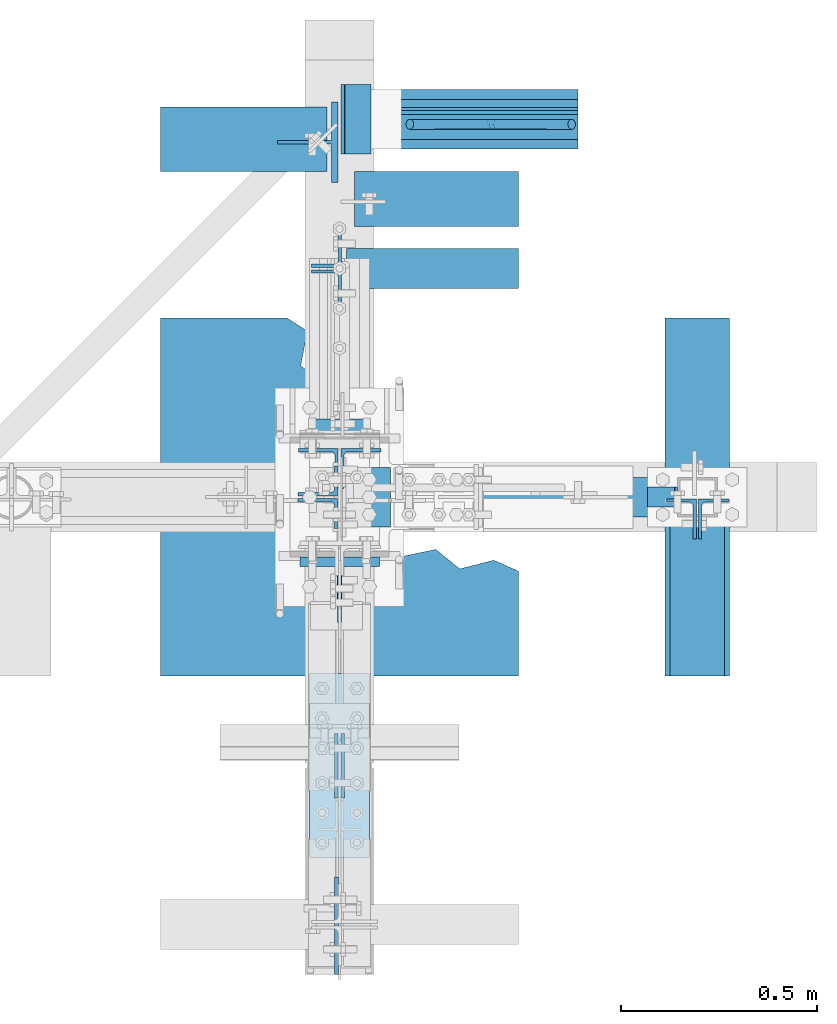
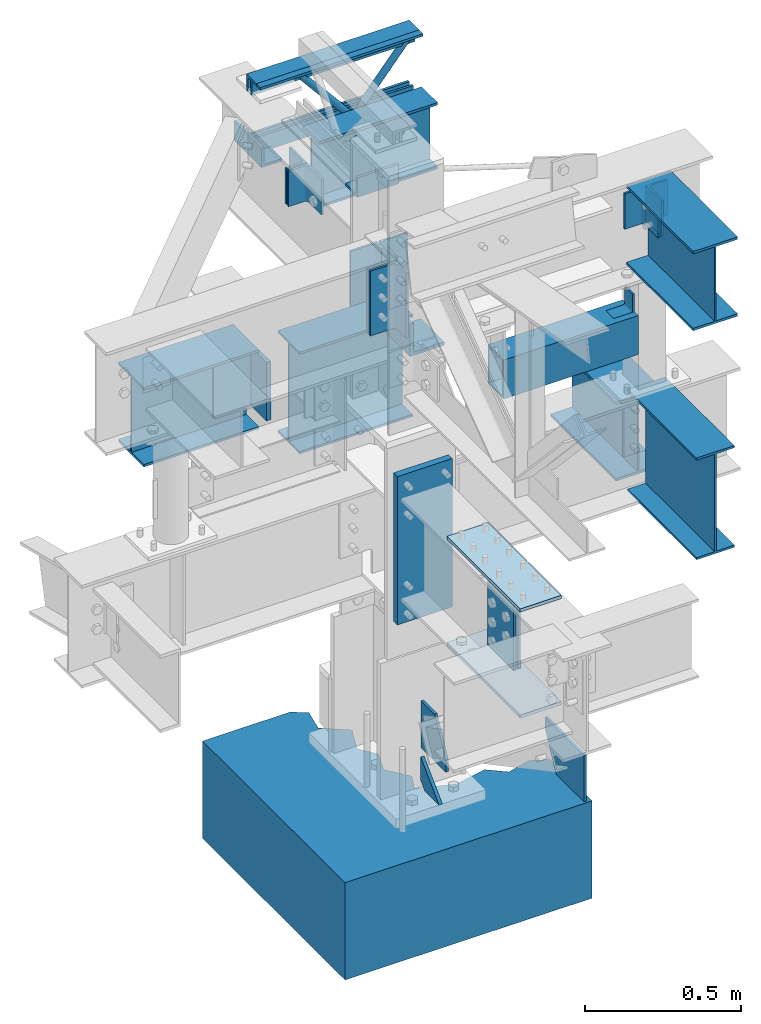
# Not in any storey, part 3 of 7: 18 members, 9 plates, 7 beams, 17 elements without a shape of their own.
"""IFC2X3 building model written with IfcOpenShell, lengths in inches."""

from ifc_helpers import new_model, entity, si_unit, converted_unit, frame, frame_2d, origin_with_axes, place, context, project, spatial, polyline, hollow_rectangle, i_section, l_section, t_section, outline, transform_2d, derived_profile, extrude, source, transform, mapped, material, type_object, type_shapes, element, aggregate, save


model = new_model("IFC2X3")

# Units and contexts
model_context = context("Model", 3, precision=1e-05, world=origin_with_axes())
ifc_project = project(units=[converted_unit("LENGTHUNIT", "INCH", entity("IfcLengthMeasure", 25.4), si_unit("LENGTHUNIT", "METRE", prefix="MILLI"), dimensions=[1, 0, 0, 0, 0, 0, 0]), si_unit("PLANEANGLEUNIT", "RADIAN"), si_unit("MASSUNIT", "GRAM", prefix="KILO"), si_unit("TIMEUNIT", "SECOND"), si_unit("AREAUNIT", "SQUARE_METRE"), si_unit("PRESSUREUNIT", "PASCAL"), si_unit("FORCEUNIT", "NEWTON"), si_unit("THERMODYNAMICTEMPERATUREUNIT", "DEGREE_CELSIUS")], contexts=[model_context])

# Site, building
site_placement = place(None, origin_with_axes())
site = spatial("IfcSite", under=ifc_project, at=site_placement, CompositionType="ELEMENT")
building_placement = place(site_placement, origin_with_axes())
building = spatial("IfcBuilding", under=site, at=building_placement, Name="Building", CompositionType="ELEMENT")

# Assembly, members
assembly_1_placement = place(building_placement, frame((0.0, 38.0, 82.5), z_axis=(0.0, 0.0, -1.0), x_axis=(1.0, 0.0, 0.0)))
assembly_1 = element("IfcElementAssembly", 1, at=assembly_1_placement, inside=building, Name="M_41", PredefinedType="NOTDEFINED")
ifc_material_1 = material()
member_type_1 = type_object("IfcMemberType", Name="L2-1/2x2-1/2x3/8", PredefinedType="USERDEFINED", material=ifc_material_1)
shared_shape_1 = source(origin_with_axes(), model_context, "Body", "SweptSolid", [
    extrude(l_section(Depth=2.5, Width=2.5, Thickness=0.375, FilletRadius=0.3125, at=frame_2d((1.25, 1.25), x_axis=(1.0, 0.0))), frame((0.0, 0.0, 0.0), z_axis=(1.0, 0.0, 0.0), x_axis=(0.0, 1.0, 0.0)), (0.0, 0.0, 1.0), 23.7500038146973),
])
type_shapes(member_type_1, [shared_shape_1])
member_1_placement = place(assembly_1_placement, frame((0.25, 0.5, 0.0), z_axis=(0.0, 0.0, 1.0), x_axis=(1.0, 0.0, 0.0)))
member_1 = element("IfcMember", 2, at=member_1_placement, type_object=member_type_1, Name="a32", ObjectType="Member", context=model_context, shape_type="MappedRepresentation", body=[
    mapped(shared_shape_1, transform((0.0, 0.0, 0.0), scale=1.0)),
])
member_type_2 = type_object("IfcMemberType", Name="L2-1/2x2-1/2x3/8", PredefinedType="USERDEFINED", material=ifc_material_1)
shared_shape_2 = source(origin_with_axes(), model_context, "Body", "SweptSolid", [
    extrude(derived_profile(l_section(Depth=2.5, Width=2.5, Thickness=0.375, FilletRadius=0.3125, at=frame_2d((1.25, 1.25), x_axis=(1.0, 0.0))), transform_2d((0.0, 0.0), x_axis=(-1.0, 0.0), y_axis=(0.0, 1.0))), frame((0.0, 0.0, 0.0), z_axis=(1.0, 0.0, 0.0), x_axis=(0.0, 1.0, 0.0)), (0.0, 0.0, 1.0), 23.7500038146973),
])
type_shapes(member_type_2, [shared_shape_2])
member_2_placement = place(assembly_1_placement, frame((0.25, -0.5, 0.0), z_axis=(0.0, 0.0, 1.0), x_axis=(1.0, 0.0, 0.0)))
member_2 = element("IfcMember", 3, at=member_2_placement, type_object=member_type_2, Name="a6", ObjectType="Member", context=model_context, shape_type="MappedRepresentation", body=[
    mapped(shared_shape_2, transform((0.0, 0.0, 0.0), scale=1.0)),
])
member_type_3 = type_object("IfcMemberType", Name="L2-1/2x2-1/2x3/8", PredefinedType="USERDEFINED", material=ifc_material_1)
shared_shape_3 = source(origin_with_axes(), model_context, "Body", "SweptSolid", [
    extrude(derived_profile(l_section(Depth=2.5, Width=2.5, Thickness=0.375, FilletRadius=0.3125, at=frame_2d((1.25, 1.25), x_axis=(1.0, 0.0))), transform_2d((0.0, 0.0), x_axis=(-1.0, 0.0), y_axis=(0.0, 1.0))), frame((0.0, 0.0, 0.0), z_axis=(1.0, 0.0, 0.0), x_axis=(0.0, 1.0, 0.0)), (0.0, 0.0, 1.0), 23.5000038146973),
])
type_shapes(member_type_3, [shared_shape_3])
member_3_placement = place(assembly_1_placement, frame((0.5, 0.5, 12.0), z_axis=(0.0, 0.0, -1.0), x_axis=(1.0, 0.0, 0.0)))
member_3 = element("IfcMember", 4, at=member_3_placement, type_object=member_type_3, Name="a37", ObjectType="Member", context=model_context, shape_type="MappedRepresentation", body=[
    mapped(shared_shape_3, transform((0.0, 0.0, 0.0), scale=1.0)),
])
member_type_4 = type_object("IfcMemberType", Name="L2-1/2x2-1/2x3/8", PredefinedType="USERDEFINED", material=ifc_material_1)
shared_shape_4 = source(origin_with_axes(), model_context, "Body", "SweptSolid", [
    extrude(l_section(Depth=2.5, Width=2.5, Thickness=0.375, FilletRadius=0.3125, at=frame_2d((1.25, 1.25), x_axis=(1.0, 0.0))), frame((0.0, 0.0, 0.0), z_axis=(1.0, 0.0, 0.0), x_axis=(0.0, 1.0, 0.0)), (0.0, 0.0, 1.0), 23.5000038146973),
])
type_shapes(member_type_4, [shared_shape_4])
member_4_placement = place(assembly_1_placement, frame((24.0000038146973, -0.5, 12.0), z_axis=(0.0, -1.0, 0.0), x_axis=(-1.0, 0.0, 0.0)))
member_4 = element("IfcMember", 5, at=member_4_placement, type_object=member_type_4, Name="a38", ObjectType="Member", context=model_context, shape_type="MappedRepresentation", body=[
    mapped(shared_shape_4, transform((0.0, 0.0, 0.0), scale=1.0)),
])

assembly_2_placement = place(building_placement, frame((0.0, 0.0, 54.5), z_axis=(0.0, -1.0, 0.0), x_axis=(0.0, 0.0, 1.0)))
assembly_2 = element("IfcElementAssembly", 6, at=assembly_2_placement, inside=building, Name="1-3", PredefinedType="NOTDEFINED")
member_type_5 = type_object("IfcMemberType", Name="L5x5x1/2", PredefinedType="USERDEFINED", material=ifc_material_1)
shared_shape_5 = source(origin_with_axes(), model_context, "Body", "SweptSolid", [
    extrude(derived_profile(l_section(Depth=5.0, Width=5.0, Thickness=0.5, FilletRadius=0.5, at=frame_2d((2.5, 2.5), x_axis=(1.0, 0.0))), transform_2d((0.0, 0.0), x_axis=(-1.0, 0.0), y_axis=(0.0, 1.0))), frame((0.0, 0.0, 0.0), z_axis=(1.0, 0.0, 0.0), x_axis=(0.0, 1.0, 0.0)), (0.0, 0.0, 1.0), 6.0),
])
type_shapes(member_type_5, [shared_shape_5])
member_5_placement = place(assembly_2_placement, frame((9.64000034332275, -0.144999995827675, 3.0), z_axis=(0.0, -1.0, 0.0), x_axis=(0.0, 0.0, -1.0)))
member_5 = element("IfcMember", 7, at=member_5_placement, type_object=member_type_5, Name="a28", ObjectType="Column", context=model_context, shape_type="MappedRepresentation", body=[
    mapped(shared_shape_5, transform((0.0, 0.0, 0.0), scale=1.0)),
])
member_type_6 = type_object("IfcMemberType", Name="L3x3x3/8", PredefinedType="USERDEFINED", material=ifc_material_1)
shared_shape_6 = source(origin_with_axes(), model_context, "Body", "SweptSolid", [
    extrude(derived_profile(l_section(Depth=3.0, Width=3.0, Thickness=0.375, FilletRadius=0.3125, at=frame_2d((1.5, 1.5), x_axis=(1.0, 0.0))), transform_2d((0.0, 0.0), x_axis=(-1.0, 0.0), y_axis=(0.0, 1.0))), frame((0.0, 0.0, 0.0), z_axis=(1.0, 0.0, 0.0), x_axis=(0.0, 1.0, 0.0)), (0.0, 0.0, 1.0), 6.0),
])
type_shapes(member_type_6, [shared_shape_6])
member_6_placement = place(assembly_2_placement, frame((30.5, -3.0, -4.86499977111816), z_axis=(0.0, 0.0, -1.0), x_axis=(0.0, 1.0, 0.0)))
member_6 = element("IfcMember", 8, at=member_6_placement, type_object=member_type_6, Name="a27", ObjectType="Column", context=model_context, shape_type="MappedRepresentation", body=[
    mapped(shared_shape_6, transform((0.0, 0.0, 0.0), scale=1.0)),
])
aggregate(assembly_2, [member_5, member_6])

# Assembly, member
assembly_3_placement = place(building_placement, frame((0.0, 0.0, 46.0), z_axis=(0.0, 0.0, 1.0), x_axis=(0.0, 1.0, 0.0)))
assembly_3 = element("IfcElementAssembly", 9, at=assembly_3_placement, inside=building, Name="2-3", PredefinedType="NOTDEFINED")
ifc_material_2 = material()
member_type_7 = type_object("IfcMemberType", Name="WT6x25", PredefinedType="USERDEFINED", material=ifc_material_2)
shared_shape_7 = source(origin_with_axes(), model_context, "Body", "SweptSolid", [
    extrude(t_section(Depth=6.095, FlangeWidth=8.08, WebThickness=0.37, FlangeThickness=0.64, at=frame_2d((0.0, -3.0475), x_axis=(1.0, 0.0))), frame((0.0, 0.0, 0.0), z_axis=(1.0, 0.0, 0.0), x_axis=(0.0, 1.0, 0.0)), (0.0, 0.0, 1.0), 9.0),
])
type_shapes(member_type_7, [shared_shape_7])
member_7_placement = place(assembly_3_placement, frame((35.6999999880791, 0.14750000834465, -12.5), z_axis=(0.0, -1.0, 0.0), x_axis=(0.0, 0.0, 1.0)))
member_7 = element("IfcMember", 10, at=member_7_placement, type_object=member_type_7, Name="wt5", ObjectType="Beam", context=model_context, shape_type="MappedRepresentation", body=[
    mapped(shared_shape_7, transform((0.0, 0.0, 0.0), scale=1.0)),
])
aggregate(assembly_3, [member_7])

# Assembly, beam
assembly_4_placement = place(building_placement, frame((36.0, 0.0, 58.0), z_axis=(0.0, 0.0, 1.0), x_axis=(-1.0, 0.0, 0.0)))
assembly_4 = element("IfcElementAssembly", 11, at=assembly_4_placement, inside=building, Name="4-3", PredefinedType="NOTDEFINED")
ifc_material_3 = material()
beam_type_1 = type_object("IfcBeamType", Name="TS6x4x1/4", PredefinedType="BEAM", material=ifc_material_3)
shared_shape_8 = source(origin_with_axes(), model_context, "Body", "SweptSolid", [
    extrude(hollow_rectangle(XDim=4.0, YDim=6.0, WallThickness=0.25, at=frame_2d((0.0, -3.0), x_axis=(1.0, 0.0))), frame((0.0, 0.0, 0.0), z_axis=(1.0, 0.0, 0.0), x_axis=(0.0, 1.0, 0.0)), (0.0, 0.0, 1.0), 19.625),
])
type_shapes(beam_type_1, [shared_shape_8])
beam_1_placement = place(assembly_4_placement, frame((21.625, 0.0, 0.0), z_axis=(0.0, 0.0, 1.0), x_axis=(-1.0, 0.0, 0.0)))
beam_1 = element("IfcBeam", 12, at=beam_1_placement, type_object=beam_type_1, Name="ts3", ObjectType="Beam", context=model_context, shape_type="MappedRepresentation", body=[
    mapped(shared_shape_8, transform((0.0, 0.0, 0.0), scale=1.0)),
])
aggregate(assembly_4, [beam_1])

# Assembly, member
assembly_5_placement = place(building_placement, frame((36.0, 0.0, 46.0), z_axis=(-1.0, 0.0, 0.0), x_axis=(0.0, 0.0, 1.0)))
assembly_5 = element("IfcElementAssembly", 13, at=assembly_5_placement, inside=building, Name="4-1", PredefinedType="NOTDEFINED")
member_type_8 = type_object("IfcMemberType", Name="L3x3x1/4", PredefinedType="USERDEFINED", material=ifc_material_1)
shared_shape_9 = source(origin_with_axes(), model_context, "Body", "SweptSolid", [
    extrude(derived_profile(l_section(Depth=3.0, Width=3.0, Thickness=0.25, FilletRadius=0.3125, at=frame_2d((1.5, 1.5), x_axis=(1.0, 0.0))), transform_2d((0.0, 0.0), x_axis=(-1.0, 0.0), y_axis=(0.0, 1.0))), frame((0.0, 0.0, 0.0), z_axis=(1.0, 0.0, 0.0), x_axis=(0.0, 1.0, 0.0)), (0.0, 0.0, 1.0), 2.0),
])
type_shapes(member_type_8, [shared_shape_9])
member_8_placement = place(assembly_5_placement, frame((11.75, 1.0, 2.0), z_axis=(0.0, 0.0, 1.0), x_axis=(0.0, -1.0, 0.0)))
member_8 = element("IfcMember", 14, at=member_8_placement, type_object=member_type_8, Name="a11", ObjectType="Column", context=model_context, shape_type="MappedRepresentation", body=[
    mapped(shared_shape_9, transform((0.0, 0.0, 0.0), scale=1.0)),
])
aggregate(assembly_5, [member_8])

# Assembly, beam
assembly_6_placement = place(building_placement, frame((36.0, 0.0, 46.0), z_axis=(0.0, 0.0, 1.0), x_axis=(0.0, -1.0, 0.0)))
assembly_6 = element("IfcElementAssembly", 15, at=assembly_6_placement, inside=building, Name="3-1", PredefinedType="NOTDEFINED")
ifc_material_4 = material()
beam_type_2 = type_object("IfcBeamType", Name="W16x26", PredefinedType="BEAM", material=ifc_material_4)
shared_shape_10 = source(origin_with_axes(), model_context, "Body", "SweptSolid", [
    extrude(i_section(OverallWidth=5.5, OverallDepth=15.69, WebThickness=0.25, FlangeThickness=0.345, at=frame_2d((0.0, -7.845), x_axis=(1.0, 0.0))), frame((0.0, 0.0, 0.0), z_axis=(1.0, 0.0, 0.0), x_axis=(0.0, 1.0, 0.0)), (0.0, 0.0, 1.0), 17.4375),
])
type_shapes(beam_type_2, [shared_shape_10])
beam_2_placement = place(assembly_6_placement, frame((0.5625, 0.0, 0.0), z_axis=(0.0, 0.0, 1.0), x_axis=(1.0, 0.0, 0.0)))
beam_2 = element("IfcBeam", 16, at=beam_2_placement, type_object=beam_type_2, Name="w3", ObjectType="Beam", context=model_context, shape_type="MappedRepresentation", body=[
    mapped(shared_shape_10, transform((0.0, 0.0, 0.0), scale=1.0)),
])
aggregate(assembly_6, [beam_2])

assembly_7_placement = place(building_placement, frame((36.0, 0.0, 43.0), z_axis=(0.0, 0.0, 1.0), x_axis=(0.0, 1.0, 0.0)))
assembly_7 = element("IfcElementAssembly", 17, at=assembly_7_placement, inside=building, Name="3-3", PredefinedType="NOTDEFINED")
beam_type_3 = type_object("IfcBeamType", Name="W12x26", PredefinedType="BEAM", material=ifc_material_4)
shared_shape_11 = source(origin_with_axes(), model_context, "Body", "SweptSolid", [
    extrude(i_section(OverallWidth=6.49, OverallDepth=12.22, WebThickness=0.23, FlangeThickness=0.38, at=frame_2d((0.0, -6.11), x_axis=(1.0, 0.0))), frame((0.0, 0.0, 0.0), z_axis=(1.0, 0.0, 0.0), x_axis=(0.0, 1.0, 0.0)), (0.0, 0.0, 1.0), 16.5),
])
type_shapes(beam_type_3, [shared_shape_11])
beam_3_placement = place(assembly_7_placement, frame((1.5, 0.0, 0.0), z_axis=(0.0, 0.0, 1.0), x_axis=(1.0, 0.0, 0.0)))
beam_3 = element("IfcBeam", 18, at=beam_3_placement, type_object=beam_type_3, Name="w13", ObjectType="Beam", context=model_context, shape_type="MappedRepresentation", body=[
    mapped(shared_shape_11, transform((0.0, 0.0, 0.0), scale=1.0)),
])
aggregate(assembly_7, [beam_3])

assembly_8_placement = place(building_placement, frame((0.0, 30.0, 46.0), z_axis=(0.0, 0.0, 1.0), x_axis=(1.0, 0.0, 0.0)))
assembly_8 = element("IfcElementAssembly", 19, at=assembly_8_placement, inside=building, Name="3-2", PredefinedType="NOTDEFINED")
beam_type_4 = type_object("IfcBeamType", Name="W16x26", PredefinedType="BEAM", material=ifc_material_4)
shared_shape_12 = source(origin_with_axes(), model_context, "Body", "SweptSolid", [
    extrude(i_section(OverallWidth=5.5, OverallDepth=15.69, WebThickness=0.25, FlangeThickness=0.345, at=frame_2d((0.0, -7.845), x_axis=(1.0, 0.0))), frame((0.0, 0.0, 0.0), z_axis=(1.0, 0.0, 0.0), x_axis=(0.0, 1.0, 0.0)), (0.0, 0.0, 1.0), 16.5),
])
type_shapes(beam_type_4, [shared_shape_12])
beam_4_placement = place(assembly_8_placement, frame((1.5, 0.0, 0.0), z_axis=(0.0, 0.0, 1.0), x_axis=(1.0, 0.0, 0.0)))
beam_4 = element("IfcBeam", 20, at=beam_4_placement, type_object=beam_type_4, Name="w16", ObjectType="Beam", context=model_context, shape_type="MappedRepresentation", body=[
    mapped(shared_shape_12, transform((0.0, 0.0, 0.0), scale=1.0)),
])
aggregate(assembly_8, [beam_4])

assembly_9_placement = place(building_placement, frame((0.0, 36.0, 44.0), z_axis=(0.0, 0.0, 1.0), x_axis=(-1.0, 0.0, 0.0)))
assembly_9 = element("IfcElementAssembly", 21, at=assembly_9_placement, inside=building, Name="3-4", PredefinedType="NOTDEFINED")
beam_type_5 = type_object("IfcBeamType", Name="W12x26", PredefinedType="BEAM", material=ifc_material_4)
shared_shape_13 = source(origin_with_axes(), model_context, "Body", "SweptSolid", [
    extrude(i_section(OverallWidth=6.49, OverallDepth=12.22, WebThickness=0.23, FlangeThickness=0.38, at=frame_2d((0.0, -6.11), x_axis=(1.0, 0.0))), frame((0.0, 0.0, 0.0), z_axis=(1.0, 0.0, 0.0), x_axis=(0.0, 1.0, 0.0)), (0.0, 0.0, 1.0), 16.75),
])
type_shapes(beam_type_5, [shared_shape_13])
beam_5_placement = place(assembly_9_placement, frame((1.25, 0.0, 0.0), z_axis=(0.0, 0.0, 1.0), x_axis=(1.0, 0.0, 0.0)))
beam_5 = element("IfcBeam", 22, at=beam_5_placement, type_object=beam_type_5, Name="w18", ObjectType="Beam", context=model_context, shape_type="MappedRepresentation", body=[
    mapped(shared_shape_13, transform((0.0, 0.0, 0.0), scale=1.0)),
])
aggregate(assembly_9, [beam_5])

# Assembly, members
assembly_10_placement = place(building_placement, frame((0.0, 23.0, 82.5), z_axis=(0.0, 0.0, 1.0), x_axis=(1.0, 0.0, 0.0)))
assembly_10 = element("IfcElementAssembly", 23, at=assembly_10_placement, inside=building, Name="3-11", PredefinedType="NOTDEFINED")
member_type_9 = type_object("IfcMemberType", Name="L4x3x5/16", PredefinedType="USERDEFINED", material=ifc_material_1)
shared_shape_14 = source(origin_with_axes(), model_context, "Body", "SweptSolid", [
    extrude(derived_profile(l_section(Depth=4.0, Width=3.0, Thickness=0.3125, FilletRadius=0.4375, at=frame_2d((1.5, 2.0), x_axis=(1.0, 0.0))), transform_2d((0.0, 0.0), x_axis=(-1.0, 0.0), y_axis=(0.0, 1.0))), frame((0.0, 0.0, 0.0), z_axis=(1.0, 0.0, 0.0), x_axis=(0.0, 1.0, 0.0)), (0.0, 0.0, 1.0), 5.5),
])
type_shapes(member_type_9, [shared_shape_14])
member_9_placement = place(assembly_10_placement, frame((0.1875, -0.125, -9.75), z_axis=(0.0, -1.0, 0.0), x_axis=(0.0, 0.0, 1.0)))
member_9 = element("IfcMember", 24, at=member_9_placement, type_object=member_type_9, Name="a31", ObjectType="Beam", context=model_context, shape_type="MappedRepresentation", body=[
    mapped(shared_shape_14, transform((0.0, 0.0, 0.0), scale=1.0)),
])
member_10_placement = place(assembly_10_placement, frame((0.1875, 0.125, -4.25), z_axis=(0.0, 1.0, 0.0), x_axis=(0.0, 0.0, -1.0)))
member_10 = element("IfcMember", 25, at=member_10_placement, type_object=member_type_9, Name="a31", ObjectType="Beam", context=model_context, shape_type="MappedRepresentation", body=[
    mapped(shared_shape_14, transform((0.0, 0.0, 0.0), scale=1.0)),
])

assembly_11_placement = place(building_placement, frame((0.0, 0.0, 80.0), z_axis=(0.0, 0.0, 1.0), x_axis=(0.0, 1.0, 0.0)))
assembly_11 = element("IfcElementAssembly", 26, at=assembly_11_placement, inside=building, Name="2-6", PredefinedType="NOTDEFINED")
member_type_10 = type_object("IfcMemberType", Name="L4x4x5/16", PredefinedType="USERDEFINED", material=ifc_material_1)
shared_shape_15 = source(origin_with_axes(), model_context, "Body", "SweptSolid", [
    extrude(derived_profile(l_section(Depth=4.0, Width=4.0, Thickness=0.3125, FilletRadius=0.375, at=frame_2d((2.0, 2.0), x_axis=(1.0, 0.0))), transform_2d((0.0, 0.0), x_axis=(-1.0, 0.0), y_axis=(0.0, 1.0))), frame((0.0, 0.0, 0.0), z_axis=(1.0, 0.0, 0.0), x_axis=(0.0, 1.0, 0.0)), (0.0, 0.0, 1.0), 8.5),
])
type_shapes(member_type_10, [shared_shape_15])
member_11_placement = place(assembly_11_placement, frame((4.875, -0.14750000834465, -11.25), z_axis=(0.0, -1.0, 0.0), x_axis=(0.0, 0.0, 1.0)))
member_11 = element("IfcMember", 27, at=member_11_placement, type_object=member_type_10, Name="a7", ObjectType="Beam", context=model_context, shape_type="MappedRepresentation", body=[
    mapped(shared_shape_15, transform((0.0, 0.0, 0.0), scale=1.0)),
])
member_12_placement = place(assembly_11_placement, frame((4.875, 0.14750000834465, -2.75), z_axis=(0.0, 1.0, 0.0), x_axis=(0.0, 0.0, -1.0)))
member_12 = element("IfcMember", 28, at=member_12_placement, type_object=member_type_10, Name="a7", ObjectType="Beam", context=model_context, shape_type="MappedRepresentation", body=[
    mapped(shared_shape_15, transform((0.0, 0.0, 0.0), scale=1.0)),
])

assembly_12_placement = place(building_placement, frame((0.0, 0.0, 80.0), z_axis=(0.0, 0.0, 1.0), x_axis=(-1.0, 0.0, 0.0)))
assembly_12 = element("IfcElementAssembly", 29, at=assembly_12_placement, inside=building, Name="2-7", PredefinedType="NOTDEFINED")
member_type_11 = type_object("IfcMemberType", Name="L4x3x5/16", PredefinedType="USERDEFINED", material=ifc_material_1)
shared_shape_16 = source(origin_with_axes(), model_context, "Body", "SweptSolid", [
    extrude(l_section(Depth=4.0, Width=3.0, Thickness=0.3125, FilletRadius=0.4375, at=frame_2d((1.5, 2.0), x_axis=(1.0, 0.0))), frame((0.0, 0.0, 0.0), z_axis=(1.0, 0.0, 0.0), x_axis=(0.0, 1.0, 0.0)), (0.0, 0.0, 1.0), 10.0),
])
type_shapes(member_type_11, [shared_shape_16])
member_13_placement = place(assembly_12_placement, frame((0.1875, -0.137500002980232, -12.75), z_axis=(1.0, 0.0, 0.0), x_axis=(0.0, 0.0, 1.0)))
member_13 = element("IfcMember", 30, at=member_13_placement, type_object=member_type_11, Name="a8", ObjectType="Beam", context=model_context, shape_type="MappedRepresentation", body=[
    mapped(shared_shape_16, transform((0.0, 0.0, 0.0), scale=1.0)),
])
member_14_placement = place(assembly_12_placement, frame((0.1875, 0.137500002980232, -2.75), z_axis=(1.0, 0.0, 0.0), x_axis=(0.0, 0.0, -1.0)))
member_14 = element("IfcMember", 31, at=member_14_placement, type_object=member_type_11, Name="a10", ObjectType="Beam", context=model_context, shape_type="MappedRepresentation", body=[
    mapped(shared_shape_16, transform((0.0, 0.0, 0.0), scale=1.0)),
])
aggregate(assembly_12, [member_13, member_14])

# Member
member_type_12 = type_object("IfcMemberType", Name="L3x3x3/8", PredefinedType="USERDEFINED", material=ifc_material_1)
shared_shape_17 = source(origin_with_axes(), model_context, "Body", "SweptSolid", [
    extrude(derived_profile(l_section(Depth=3.0, Width=3.0, Thickness=0.375, FilletRadius=0.3125, at=frame_2d((1.5, 1.5), x_axis=(1.0, 0.0))), transform_2d((0.0, 0.0), x_axis=(-1.0, 0.0), y_axis=(0.0, 1.0))), frame((0.0, 0.0, 0.0), z_axis=(1.0, 0.0, 0.0), x_axis=(0.0, 1.0, 0.0)), (0.0, 0.0, 1.0), 7.0),
])
type_shapes(member_type_12, [shared_shape_17])
member_15_placement = place(assembly_11_placement, frame((34.5, -0.14750000834465, -9.5), z_axis=(0.0, -1.0, 0.0), x_axis=(1.0, 0.0, 0.0)))
member_15 = element("IfcMember", 32, at=member_15_placement, type_object=member_type_12, Name="a35", ObjectType="Beam", context=model_context, shape_type="MappedRepresentation", body=[
    mapped(shared_shape_17, transform((0.0, 0.0, 0.0), scale=1.0)),
])

aggregate(assembly_11, [member_11, member_12, member_15])

# Assembly, members, beam
assembly_13_placement = place(building_placement, frame((36.0, 0.0, 78.0), z_axis=(0.0, 0.0, 1.0), x_axis=(0.0, -1.0, 0.0)))
assembly_13 = element("IfcElementAssembly", 33, at=assembly_13_placement, inside=building, Name="3-9", PredefinedType="NOTDEFINED")
member_type_13 = type_object("IfcMemberType", Name="L4x3x5/16", PredefinedType="USERDEFINED", material=ifc_material_1)
shared_shape_18 = source(origin_with_axes(), model_context, "Body", "SweptSolid", [
    extrude(l_section(Depth=4.0, Width=3.0, Thickness=0.3125, FilletRadius=0.4375, at=frame_2d((1.5, 2.0), x_axis=(1.0, 0.0))), frame((0.0, 0.0, 0.0), z_axis=(1.0, 0.0, 0.0), x_axis=(0.0, 1.0, 0.0)), (0.0, 0.0, 1.0), 5.5),
])
type_shapes(member_type_13, [shared_shape_18])
member_16_placement = place(assembly_13_placement, frame((0.1875, -0.115000002086163, -7.25), z_axis=(1.0, 0.0, 0.0), x_axis=(0.0, 0.0, 1.0)))
member_16 = element("IfcMember", 34, at=member_16_placement, type_object=member_type_13, Name="a5", ObjectType="Beam", context=model_context, shape_type="MappedRepresentation", body=[
    mapped(shared_shape_18, transform((0.0, 0.0, 0.0), scale=1.0)),
])
member_17_placement = place(assembly_13_placement, frame((0.1875, 0.115000002086163, -1.75), z_axis=(1.0, 0.0, 0.0), x_axis=(0.0, 0.0, -1.0)))
member_17 = element("IfcMember", 35, at=member_17_placement, type_object=member_type_13, Name="a5", ObjectType="Beam", context=model_context, shape_type="MappedRepresentation", body=[
    mapped(shared_shape_18, transform((0.0, 0.0, 0.0), scale=1.0)),
])
beam_type_6 = type_object("IfcBeamType", Name="W12x26", PredefinedType="BEAM", material=ifc_material_4)
shared_shape_19 = source(origin_with_axes(), model_context, "Body", "SweptSolid", [
    extrude(i_section(OverallWidth=6.49, OverallDepth=12.22, WebThickness=0.23, FlangeThickness=0.38, at=frame_2d((0.0, -6.11), x_axis=(1.0, 0.0))), frame((0.0, 0.0, 0.0), z_axis=(1.0, 0.0, 0.0), x_axis=(0.0, 1.0, 0.0)), (0.0, 0.0, 1.0), 16.8125),
])
type_shapes(beam_type_6, [shared_shape_19])
beam_6_placement = place(assembly_13_placement, frame((1.1875, 0.0, 0.0), z_axis=(0.0, 0.0, 1.0), x_axis=(1.0, 0.0, 0.0)))
beam_6 = element("IfcBeam", 36, at=beam_6_placement, type_object=beam_type_6, Name="w2", ObjectType="Beam", context=model_context, shape_type="MappedRepresentation", body=[
    mapped(shared_shape_19, transform((0.0, 0.0, 0.0), scale=1.0)),
])
aggregate(assembly_13, [member_16, member_17, beam_6])

# Beam
beam_type_7 = type_object("IfcBeamType", Name="W10x19", PredefinedType="BEAM", material=ifc_material_4)
shared_shape_20 = source(origin_with_axes(), model_context, "Body", "SweptSolid", [
    extrude(i_section(OverallWidth=4.02, OverallDepth=10.24, WebThickness=0.25, FlangeThickness=0.395, at=frame_2d((0.0, -5.12), x_axis=(1.0, 0.0))), frame((0.0, 0.0, 0.0), z_axis=(1.0, 0.0, 0.0), x_axis=(0.0, 1.0, 0.0)), (0.0, 0.0, 1.0), 17.3125),
])
type_shapes(beam_type_7, [shared_shape_20])
beam_7_placement = place(assembly_10_placement, frame((0.6875, 0.0, 0.0), z_axis=(0.0, 0.0, 1.0), x_axis=(1.0, 0.0, 0.0)))
beam_7 = element("IfcBeam", 37, at=beam_7_placement, type_object=beam_type_7, Name="w17", ObjectType="Beam", context=model_context, shape_type="MappedRepresentation", body=[
    mapped(shared_shape_20, transform((0.0, 0.0, 0.0), scale=1.0)),
])

aggregate(assembly_10, [member_9, member_10, beam_7])

# Member
member_18_placement = place(assembly_1_placement, frame((23.4185070188086, 0.497068971505183, 1.55131149292049), z_axis=(0.0, 1.0, 0.0), x_axis=(0.642285189490803, 0.0, 0.766465743109738)))
cartesian_point = entity("IfcCartesianPoint", [0.0, 0.0, 0.0])
ifc_direction = entity("IfcDirection", [0.0, 0.0, 1.0])
member_18 = element("IfcMember", 38, at=member_18_placement, Name="rb2", ObjectType="Member", context=model_context, shape_type="SweptSolid", body=[
    entity("IfcSurfaceCurveSweptAreaSolid", entity("IfcCircleProfileDef", "AREA", None, entity("IfcAxis2Placement2D", entity("IfcCartesianPoint", [0.0, 0.0]), entity("IfcDirection", [1.0, 0.0])), 0.5), entity("IfcAxis2Placement3D", cartesian_point, ifc_direction, entity("IfcDirection", [1.0, 0.0, 0.0])), entity("IfcPolyline", [entity("IfcCartesianPoint", [-0.0454, -0.05412]), entity("IfcCartesianPoint", [1.9215, -11.20844]), entity("IfcCartesianPoint", [1.9183, -11.61735]), entity("IfcCartesianPoint", [1.7879, -11.96562]), entity("IfcCartesianPoint", [1.5227, -12.27681]), entity("IfcCartesianPoint", [1.199, -12.45983]), entity("IfcCartesianPoint", [0.7957, -12.52769]), entity("IfcCartesianPoint", [-10.4979, -12.52762])]), 0.0, 1.0, entity("IfcPlane", entity("IfcAxis2Placement3D", cartesian_point, entity("IfcDirection", [0.0, 1.0, 0.0]), ifc_direction))),
])

aggregate(assembly_1, [member_2, member_1, member_18, member_3, member_4])

# Assembly, plate
assembly_14_placement = place(building_placement, frame((-18.0, -18.0, -1.5), z_axis=(0.0, -1.0, 0.0), x_axis=(0.0, 0.0, 1.0)))
assembly_14 = element("IfcElementAssembly", 39, at=assembly_14_placement, inside=building, Name="M_51", PredefinedType="NOTDEFINED")
ifc_material_5 = material()
plate_type_1 = type_object("IfcPlateType", Name="Plate (Complex)", PredefinedType="SHEET", material=ifc_material_5)
shared_shape_21 = source(origin_with_axes(), model_context, "Body", "SweptSolid", [
    extrude(outline(polyline([(-33.526769, -11.664245), (-36.0, -10.560123), (-36.0, 0.0), (0.0, 0.0), (0.0, -36.0), (-12.752702, -36.0), (-14.769598, -34.714724), (-14.102677, -31.213385), (-17.604015, -28.670746), (-16.061759, -24.794264), (-17.812428, -22.418355), (-16.686998, -19.12543), (-19.062906, -16.0826), (-17.979159, -13.581645), (-23.106119, -11.789292), (-27.691205, -12.747993), (-30.108795, -10.78891), (-33.526769, -11.664245)])), frame((-7.5, 0.0, 0.0), z_axis=(1.0, 0.0, 0.0), x_axis=(0.0, 1.0, 0.0)), (0.0, 0.0, 1.0), 15.0),
])
type_shapes(plate_type_1, [shared_shape_21])
plate_1_placement = place(assembly_14_placement, frame((-7.5, 0.0, 0.0), z_axis=(0.0, 0.0, 1.0), x_axis=(1.0, 0.0, 0.0)))
plate_1 = element("IfcPlate", 40, at=plate_1_placement, type_object=plate_type_1, Name="p58", ObjectType="Member", context=model_context, shape_type="MappedRepresentation", body=[
    mapped(shared_shape_21, transform((0.0, 0.0, 0.0), scale=1.0)),
])
aggregate(assembly_14, [plate_1])

# Assembly, plates
assembly_15_placement = place(building_placement, frame((0.0, 0.0, -1.5), z_axis=(0.0, -1.0, 0.0), x_axis=(0.0, 0.0, 1.0)))
assembly_15 = element("IfcElementAssembly", 41, at=assembly_15_placement, inside=building, Name="1-1", PredefinedType="NOTDEFINED")
plate_type_2 = type_object("IfcPlateType", Name="Plate (Complex)", PredefinedType="SHEET", material=ifc_material_5)
shared_shape_22 = source(origin_with_axes(), model_context, "Body", "SweptSolid", [
    extrude(outline(polyline([(-6.355, -5.002064), (-9.7925, -5.002064), (-12.605, 0.310436), (-12.605, 2.247936), (-6.355, 2.247936), (-6.355, -5.002064)])), frame((-0.1875, 0.0, 0.0), z_axis=(1.0, 0.0, 0.0), x_axis=(0.0, 1.0, 0.0)), (0.0, 0.0, 1.0), 0.375),
])
type_shapes(plate_type_2, [shared_shape_22])
plate_2_placement = place(assembly_15_placement, frame((9.74793626708778, 0.0, 1.38770374746855e-07), z_axis=(-1.0, 0.0, 0.0), x_axis=(0.0, 1.0, 0.0)))
plate_2 = element("IfcPlate", 42, at=plate_2_placement, type_object=plate_type_2, Name="p59", ObjectType="Column", context=model_context, shape_type="MappedRepresentation", body=[
    mapped(shared_shape_22, transform((0.0, 0.0, 0.0), scale=1.0)),
])
plate_type_3 = type_object("IfcPlateType", Name="Plate (Complex)", PredefinedType="SHEET", material=ifc_material_5)
shared_shape_23 = source(origin_with_axes(), model_context, "Body", "SweptSolid", [
    extrude(outline(polyline([(-4.625, -4.625), (-4.625, -1.0), (-3.625, 0.0), (0.0, 0.0), (-4.625, -4.625)])), frame((-0.25, 0.0, 0.0), z_axis=(1.0, 0.0, 0.0), x_axis=(0.0, 1.0, 0.0)), (0.0, 0.0, 1.0), 0.5),
])
type_shapes(plate_type_3, [shared_shape_23])
plate_3_placement = place(assembly_15_placement, frame((6.125, 0.0, 6.375), z_axis=(0.0, 0.0, -1.0), x_axis=(0.0, 1.0, 0.0)))
plate_3 = element("IfcPlate", 43, at=plate_3_placement, type_object=plate_type_3, Name="p41", ObjectType="Column", context=model_context, shape_type="MappedRepresentation", body=[
    mapped(shared_shape_23, transform((0.0, 0.0, 0.0), scale=1.0)),
])
aggregate(assembly_15, [plate_2, plate_3])

assembly_16_placement = place(building_placement, frame((0.0, 0.0, 46.0), z_axis=(0.0, 0.0, 1.0), x_axis=(0.0, -1.0, 0.0)))
assembly_16 = element("IfcElementAssembly", 44, at=assembly_16_placement, inside=building, Name="2-1", PredefinedType="NOTDEFINED")
plate_type_4 = type_object("IfcPlateType", Name="Plate (6 1/2x1-0)", PredefinedType="SHEET", material=ifc_material_5)
shared_shape_24 = source(origin_with_axes(), model_context, "Body", "SweptSolid", [
    extrude(outline(polyline([(0.0, -6.5), (-12.0, -6.5), (-12.0, 0.0), (0.0, 0.0), (0.0, -6.5)])), frame((-0.1875, 0.0, 0.0), z_axis=(1.0, 0.0, 0.0), x_axis=(0.0, 1.0, 0.0)), (0.0, 0.0, 1.0), 0.375),
])
type_shapes(plate_type_4, [shared_shape_24])
plate_4_placement = place(assembly_16_placement, frame((30.25, -0.33500000834465, -1.5), z_axis=(1.0, 0.0, 0.0), x_axis=(0.0, 1.0, 0.0)))
plate_4 = element("IfcPlate", 45, at=plate_4_placement, type_object=plate_type_4, Name="p5", ObjectType="Beam", context=model_context, shape_type="MappedRepresentation", body=[
    mapped(shared_shape_24, transform((0.0, 0.0, 0.0), scale=1.0)),
])
plate_5_placement = place(assembly_16_placement, frame((30.25, 0.33500000834465, -1.5), z_axis=(1.0, 0.0, 0.0), x_axis=(0.0, 1.0, 0.0)))
plate_5 = element("IfcPlate", 46, at=plate_5_placement, type_object=plate_type_4, Name="p5", ObjectType="Beam", context=model_context, shape_type="MappedRepresentation", body=[
    mapped(shared_shape_24, transform((0.0, 0.0, 0.0), scale=1.0)),
])
plate_type_5 = type_object("IfcPlateType", Name="Plate (1-6 1/2x0-6)", PredefinedType="SHEET", material=ifc_material_5)
shared_shape_25 = source(origin_with_axes(), model_context, "Body", "SweptSolid", [
    extrude(outline(polyline([(3.0, -18.5), (-3.0, -18.5), (-3.0, 0.0), (3.0, 0.0), (3.0, -18.5)])), frame((-0.25, 0.0, 0.0), z_axis=(1.0, 0.0, 0.0), x_axis=(0.0, 1.0, 0.0)), (0.0, 0.0, 1.0), 0.5),
])
type_shapes(plate_type_5, [shared_shape_25])
plate_6_placement = place(assembly_16_placement, frame((36.25, 0.0, 0.25), z_axis=(1.0, 0.0, 0.0), x_axis=(0.0, 0.0, -1.0)))
plate_6 = element("IfcPlate", 47, at=plate_6_placement, type_object=plate_type_5, Name="p7", ObjectType="Beam", context=model_context, shape_type="MappedRepresentation", body=[
    mapped(shared_shape_25, transform((0.0, 0.0, 0.0), scale=1.0)),
])
plate_7_placement = place(assembly_16_placement, frame((36.25, 0.0, -16.1099996566772), z_axis=(1.0, 0.0, 0.0), x_axis=(0.0, 0.0, -1.0)))
plate_7 = element("IfcPlate", 48, at=plate_7_placement, type_object=plate_type_5, Name="p7", ObjectType="Beam", context=model_context, shape_type="MappedRepresentation", body=[
    mapped(shared_shape_25, transform((0.0, 0.0, 0.0), scale=1.0)),
])
plate_type_6 = type_object("IfcPlateType", Name="Plate (1-10 7/8x0-8)", PredefinedType="SHEET", material=ifc_material_5)
shared_shape_26 = source(origin_with_axes(), model_context, "Body", "SweptSolid", [
    extrude(outline(polyline([(4.0, -22.875), (-4.0, -22.875), (-4.0, 0.0), (4.0, 0.0), (4.0, -22.875)])), frame((-0.5, 0.0, 0.0), z_axis=(1.0, 0.0, 0.0), x_axis=(0.0, 1.0, 0.0)), (0.0, 0.0, 1.0), 1.0),
])
type_shapes(plate_type_6, [shared_shape_26])
plate_8_placement = place(assembly_16_placement, frame((6.5, 0.0, 3.5), z_axis=(0.0, 0.0, 1.0), x_axis=(-1.0, 0.0, 0.0)))
plate_8 = element("IfcPlate", 49, at=plate_8_placement, type_object=plate_type_6, Name="p24", ObjectType="Beam", context=model_context, shape_type="MappedRepresentation", body=[
    mapped(shared_shape_26, transform((0.0, 0.0, 0.0), scale=1.0)),
])
aggregate(assembly_16, [plate_4, plate_5, plate_6, plate_7, plate_8])

# Assembly, plate
assembly_17_placement = place(building_placement, frame((0.0, -27.0, 46.0), z_axis=(0.0, 0.0, 1.0), x_axis=(0.0, -1.0, 0.0)))
assembly_17 = element("IfcElementAssembly", 50, at=assembly_17_placement, inside=building, Name="2-2", PredefinedType="NOTDEFINED")
plate_type_7 = type_object("IfcPlateType", Name="Plate (Complex)", PredefinedType="SHEET", material=ifc_material_5)
shared_shape_27 = source(origin_with_axes(), model_context, "Body", "SweptSolid", [
    extrude(outline(polyline([(0.0, -9.8125), (-1.8125, -9.8125), (-7.125, -7.0), (-7.125001, 0.0), (0.0, 0.0), (0.0, -9.8125)])), frame((-0.1875, 0.0, 0.0), z_axis=(1.0, 0.0, 0.0), x_axis=(0.0, 1.0, 0.0)), (0.0, 0.0, 1.0), 0.375),
])
type_shapes(plate_type_7, [shared_shape_27])
plate_9_placement = place(assembly_17_placement, frame((20.999999265308, -0.302501678466797, -15.8600003826132), z_axis=(1.0, 0.0, 0.0), x_axis=(0.0, 1.0, 0.0)))
plate_9 = element("IfcPlate", 51, at=plate_9_placement, type_object=plate_type_7, Name="p6", ObjectType="Beam", context=model_context, shape_type="MappedRepresentation", body=[
    mapped(shared_shape_27, transform((0.0, 0.0, 0.0), scale=1.0)),
])
aggregate(assembly_17, [plate_9])

save(model, "model.ifc")
